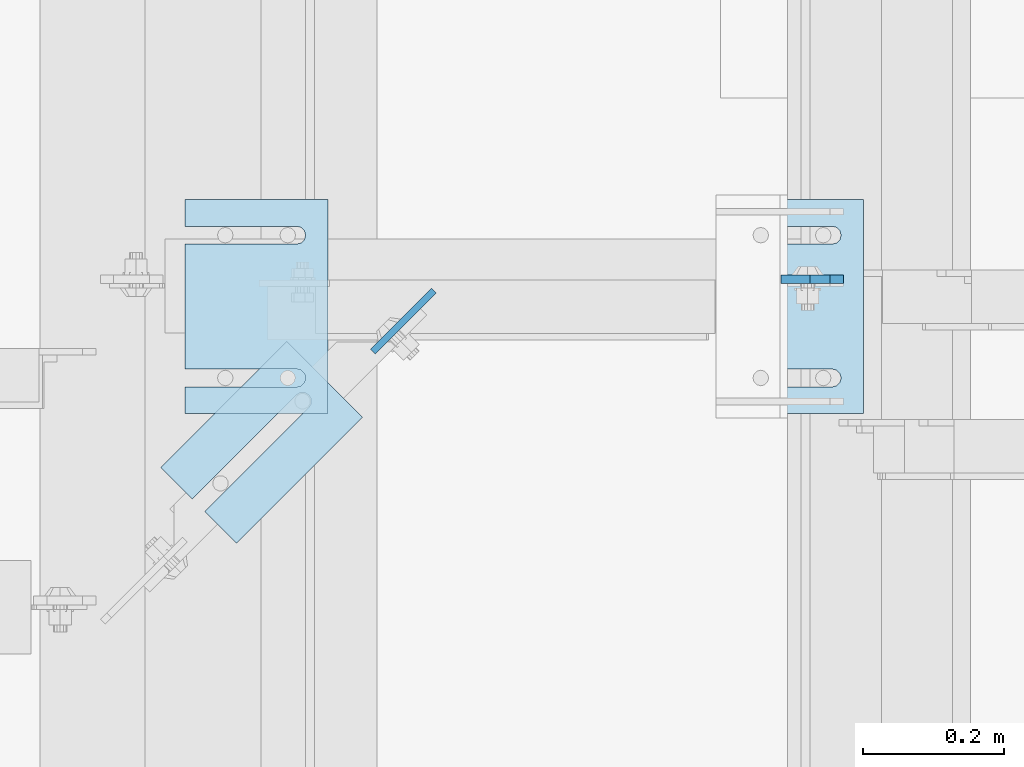
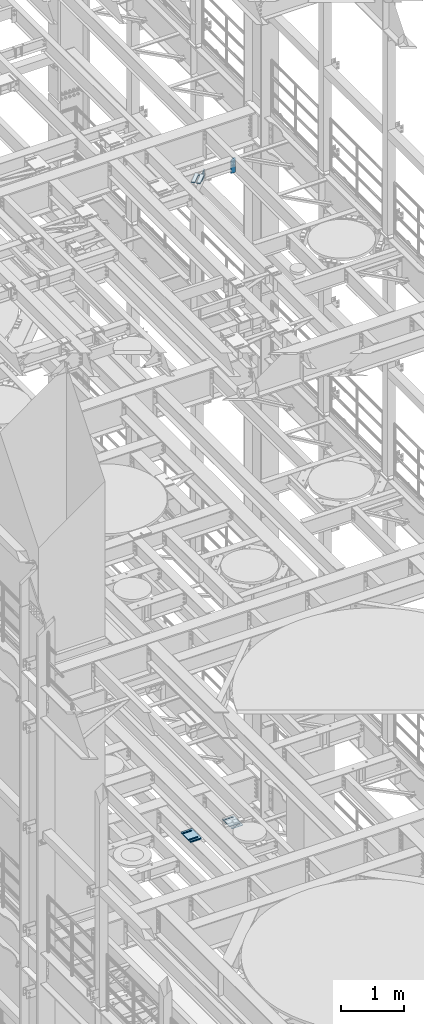
# One storey, part 1727 of 1876: 10 plates, 10 elements without a shape of their own.
"""IFC2X3 building model written with IfcOpenShell, lengths in millimetres."""

from ifc_helpers import new_model, si_unit, frame, origin_with_axes, place, context, subcontext, project, spatial, faceted_brep, material, type_object, element, aggregate, save


model = new_model("IFC2X3")

# Units and contexts
model_context = context("Model", 3, precision=1e-05, world=origin_with_axes())
body_context = subcontext(model_context, "Body", "Model", "MODEL_VIEW")
ifc_project = project(units=[si_unit("LENGTHUNIT", "METRE", prefix="MILLI"), si_unit("AREAUNIT", "SQUARE_METRE"), si_unit("VOLUMEUNIT", "CUBIC_METRE"), si_unit("MASSUNIT", "GRAM", prefix="KILO"), si_unit("TIMEUNIT", "SECOND"), si_unit("PLANEANGLEUNIT", "RADIAN"), si_unit("SOLIDANGLEUNIT", "STERADIAN"), si_unit("THERMODYNAMICTEMPERATUREUNIT", "DEGREE_CELSIUS"), si_unit("LUMINOUSINTENSITYUNIT", "LUMEN")], contexts=[model_context])

# Site, building, storey
site_placement = place(None, origin_with_axes())
site = spatial("IfcSite", under=ifc_project, at=site_placement, CompositionType="ELEMENT")
building_placement = place(site_placement, origin_with_axes())
building = spatial("IfcBuilding", under=site, at=building_placement, Name="Undefined", CompositionType="ELEMENT")
storey_placement = place(building_placement, origin_with_axes())
storey = spatial("IfcBuildingStorey", under=building, at=storey_placement, Name="Undefined", CompositionType="ELEMENT", Elevation=0.0)

# Assembly, plate
assembly_1_placement = place(storey_placement, origin_with_axes())
assembly_1 = element("IfcElementAssembly", 1, at=assembly_1_placement, inside=storey, Name="BEAM", AssemblyPlace="NOTDEFINED", PredefinedType="RIGID_FRAME")
ifc_material = material(Name="STEEL/A36")
plate_type_1 = type_object("IfcPlateType", PredefinedType="NOTDEFINED")
plate_1_placement = place(assembly_1_placement, frame((6562.72500011396, 6600.23089609146, 17686.3375), z_axis=(0.0, 0.0, 1.0), x_axis=(-1.0, 0.0, 0.0)))
plate_1 = element("IfcPlate", 2, at=plate_1_placement, type_object=plate_type_1, material=ifc_material, Name="PLATE", context=body_context, shape_type="Brep", body=[
    faceted_brep([(0.0, -6.35000000000196, 19.0499992370605), (0.0, -6.35000000000036, 271.462512969971), (0.0, 6.35000000000036, 271.462512969971), (0.0, 6.35000000000105, 19.0499992370605), (19.0499992370605, -6.35000000000036, 290.512512207031), (19.0499992370605, 6.35000000000036, 290.512512207031), (47.625, -6.35000000000036, 290.512512207031), (47.625, 6.35000000000036, 290.512512207031), (88.9000015258789, -6.35000000000036, 249.237510681152), (88.9000015258789, 6.35000000000036, 249.237510681152), (88.9000015258789, -6.34999999999991, 0.0), (88.9000015258789, 6.34999999999991, 0.0), (19.0499992370642, -6.35000000000105, 0.0), (19.0499992370633, 6.35000000000105, 0.0)], [[[0, 1, 2, 3]], [[1, 4, 5, 2]], [[4, 6, 7, 5]], [[6, 8, 9, 7]], [[8, 10, 11, 9]], [[10, 12, 13, 11]], [[12, 0, 3, 13]], [[5, 7, 9, 11, 13, 3, 2]], [[12, 10, 8, 6, 4, 1, 0]]]),
])
aggregate(assembly_1, [plate_1])

assembly_2_placement = place(storey_placement, origin_with_axes())
assembly_2 = element("IfcElementAssembly", 3, at=assembly_2_placement, inside=storey, Name="SHIM PLATE", AssemblyPlace="NOTDEFINED", PredefinedType="RIGID_FRAME")
plate_type_2 = type_object("IfcPlateType", PredefinedType="NOTDEFINED")
plate_2_placement = place(assembly_2_placement, frame((5770.7454778151, 6511.9559186681, 17987.9625), z_axis=(0.707131811743501, -0.707081749743517, 0.0), x_axis=(-0.707081749743517, -0.707131811743501, 0.0)))
plate_2 = element("IfcPlate", 4, at=plate_2_placement, type_object=plate_type_2, material=ifc_material, Name="SHIM PLATE", context=body_context, shape_type="Brep", body=[
    faceted_brep([(253.99911499016, -4.76250000000073, 63.5055228916333), (253.99911499016, 4.76250000000073, 63.5055228916333), (44.4486554352097, 4.76250000000073, 63.5055231271683), (44.4486554352097, -4.76250000000073, 63.5055231271683), (38.0987169747041, 4.76250000000073, 65.2072262109043), (38.0987169747041, -4.76250000000073, 65.2072262109043), (33.4503601482265, 4.76250000000073, 69.8559131923128), (33.4503601482265, -4.76250000000073, 69.8559131923128), (31.749108064505, 4.76250000000073, 76.2059724979433), (31.749108064505, -4.76250000000073, 76.2059724979433), (33.4508097177422, 4.76250000000073, 82.5559113418037), (33.4508097177422, -4.76250000000073, 82.5559113418037), (38.0994956519826, 4.76250000000073, 87.2042692155253), (38.0994956519826, -4.76250000000073, 87.2042692155253), (44.4495545743594, 4.76250000000073, 88.9055227297738), (44.4495545743594, -4.76250000000073, 88.9055227297738), (253.999114989845, -4.76250000000073, 88.8981048472285), (253.999114990162, 4.76250000000073, 88.8981048472285), (253.999114990156, -4.76250000000073, 2.95585778076202e-12), (0.0, -4.76249999999982, 0.0), (0.0, 4.76249999999982, 0.0), (253.999114990156, 4.76250000000073, 2.95585778076202e-12), (0.00539501897037553, -4.76250000000073, 152.405197143508), (0.00539501897037553, 4.76250000000073, 152.405197143508), (253.999114990165, -4.76250000000073, 152.405197143493), (253.999114990165, 4.76250000000073, 152.405197143493)], [[[0, 1, 2, 3]], [[3, 2, 4, 5]], [[5, 4, 6, 7]], [[7, 6, 8, 9]], [[9, 8, 10, 11]], [[11, 10, 12, 13]], [[13, 12, 14, 15]], [[16, 15, 14, 17]], [[18, 19, 20, 21]], [[19, 22, 23, 20]], [[22, 24, 25, 23]], [[25, 24, 16, 17]], [[12, 10, 8, 6, 4, 2, 1, 21, 20, 23, 25, 17, 14]], [[18, 21, 1, 0]], [[24, 22, 19, 18, 0, 3, 5, 7, 9, 11, 13, 15, 16]]]),
])
aggregate(assembly_2, [plate_2])

assembly_3_placement = place(storey_placement, origin_with_axes())
assembly_3 = element("IfcElementAssembly", 5, at=assembly_3_placement, inside=storey, Name="SHIM PLATE", AssemblyPlace="NOTDEFINED", PredefinedType="RIGID_FRAME")
plate_type_3 = type_object("IfcPlateType", PredefinedType="NOTDEFINED")
plate_3_placement = place(assembly_3_placement, frame((5829.30163873308, 6713.78228759766, 5156.9925), z_axis=(0.0, -1.0, 0.0), x_axis=(-1.0, 0.0, 0.0)))
plate_3 = element("IfcPlate", 6, at=plate_3_placement, type_object=plate_type_3, material=ifc_material, Name="SHIM PLATE", context=body_context, shape_type="Brep", body=[
    faceted_brep([(203.203060149864, -0.793499999999767, 38.103375484061), (203.203060149864, 0.793499999999767, 38.103375484061), (44.4515180349072, 0.793499999999767, 38.1033599194234), (44.4515180349072, -0.793499999999767, 38.1033599194234), (38.1012989900946, 0.793499999999767, 39.8049650059329), (38.1012989900946, -0.793499999999767, 39.8049650059329), (33.4527432566938, 0.793499999999767, 44.4538004924834), (33.4527432566938, -0.793499999999767, 44.4538004924834), (31.7515203221337, 0.793499999999767, 50.8041219264314), (31.7515203221337, -0.793499999999767, 50.8041219264314), (33.4535054350818, 0.793499999999767, 57.1542391271487), (33.4535054350818, -0.793499999999767, 57.1542391271487), (38.1026191065821, 0.793499999999767, 61.8025166422076), (38.1026191065821, -0.793499999999767, 61.8025166422076), (44.4530423390133, 0.793499999999767, 63.5033595381083), (44.4530423390133, -0.793499999999767, 63.5033595381083), (203.203057597802, -0.793499999999767, 63.5033693805453), (203.203057606771, 0.793499999999767, 63.5033693805453), (203.203063964842, -0.793499999999767, -8.45830072648823e-11), (9.09494701772928e-13, -0.793499999999767, 0.0), (9.09494701772928e-13, 0.793499999999767, 0.0), (203.203063964842, 0.793499999999767, -8.45830072648823e-11), (-1.83106603799388e-05, -0.793499999999767, 304.8037109375), (-1.83106603799388e-05, 0.793499999999767, 304.8037109375), (203.203033447349, -0.793499999999767, 304.803710937444), (203.203033447349, 0.793499999999767, 304.803710937444), (203.20303725321, -0.793499999999767, 266.701819087575), (203.203037262178, 0.793499999999767, 266.701819087575), (44.4530372532099, -0.793499999999767, 266.701809245139), (44.4530372532099, 0.793499999999767, 266.701809245139), (38.1026140207787, -0.793499999999767, 265.000966349239), (38.1026140207787, 0.793499999999767, 265.000966349239), (33.4535003492774, -0.793499999999767, 260.352688834179), (33.4535003492774, 0.793499999999767, 260.352688834179), (31.7515152363312, -0.793499999999767, 254.002571633462), (31.7515152363312, 0.793499999999767, 254.002571633462), (33.4527381708904, -0.793499999999767, 247.652250199514), (33.4527381708904, 0.793499999999767, 247.652250199514), (38.1012939042912, -0.793499999999767, 243.003414712964), (38.1012939042912, 0.793499999999767, 243.003414712964), (44.4515129491037, -0.793499999999767, 241.301809626454), (44.4515129491037, 0.793499999999767, 241.301809626454), (203.203039805271, -0.793499999999767, 241.301825191091), (203.203039805271, 0.793499999999767, 241.301825191091)], [[[0, 1, 2, 3]], [[3, 2, 4, 5]], [[5, 4, 6, 7]], [[7, 6, 8, 9]], [[9, 8, 10, 11]], [[11, 10, 12, 13]], [[13, 12, 14, 15]], [[16, 15, 14, 17]], [[18, 19, 20, 21]], [[19, 22, 23, 20]], [[22, 24, 25, 23]], [[25, 24, 26, 27]], [[26, 28, 29, 27]], [[30, 31, 29, 28]], [[32, 33, 31, 30]], [[34, 35, 33, 32]], [[36, 37, 35, 34]], [[38, 39, 37, 36]], [[40, 41, 39, 38]], [[42, 43, 41, 40]], [[43, 42, 16, 17]], [[12, 10, 8, 6, 4, 2, 1, 21, 20, 23, 25, 27, 29, 31, 33, 35, 37, 39, 41, 43, 17, 14]], [[18, 21, 1, 0]], [[42, 40, 38, 36, 34, 32, 30, 28, 26, 24, 22, 19, 18, 0, 3, 5, 7, 9, 11, 13, 15, 16]]]),
])
aggregate(assembly_3, [plate_3])

assembly_4_placement = place(storey_placement, origin_with_axes())
assembly_4 = element("IfcElementAssembly", 7, at=assembly_4_placement, inside=storey, Name="SHIM PLATE", AssemblyPlace="NOTDEFINED", PredefinedType="RIGID_FRAME")
plate_type_4 = type_object("IfcPlateType", PredefinedType="NOTDEFINED")
plate_4_placement = place(assembly_4_placement, frame((5829.30163873308, 6713.78228759766, 5154.6115), z_axis=(0.0, -1.0, 0.0), x_axis=(-1.0, 0.0, 0.0)))
plate_4 = element("IfcPlate", 8, at=plate_4_placement, type_object=plate_type_4, material=ifc_material, Name="SHIM PLATE", context=body_context, shape_type="Brep", body=[
    faceted_brep([(203.203060149865, -1.58749999999964, 38.1033754840619), (203.203060149865, 1.58749999999964, 38.1033754840619), (44.4515180349081, 1.58749999999964, 38.1033599194243), (44.4515180349081, -1.58749999999964, 38.1033599194243), (38.1012989900955, 1.58749999999964, 39.8049650059338), (38.1012989900955, -1.58749999999964, 39.8049650059338), (33.4527432566947, 1.58749999999964, 44.4538004924843), (33.4527432566947, -1.58749999999964, 44.4538004924843), (31.7515203221346, 1.58749999999964, 50.8041219264323), (31.7515203221346, -1.58749999999964, 50.8041219264323), (33.4535054350827, 1.58749999999964, 57.1542391271496), (33.4535054350827, -1.58749999999964, 57.1542391271496), (38.102619106583, 1.58749999999964, 61.8025166422085), (38.102619106583, -1.58749999999964, 61.8025166422085), (44.4530423390142, 1.58749999999964, 63.5033595381092), (44.4530423390142, -1.58749999999964, 63.5033595381092), (203.203057597803, -1.58749999999964, 63.5033693805462), (203.203057606772, 1.58749999999964, 63.5033693805462), (203.203063964843, -1.58749999999964, -8.36735125631094e-11), (9.09494701772928e-13, -1.58750000000146, 4.54747350886464e-13), (9.09494701772928e-13, 1.58750000000146, 4.54747350886464e-13), (203.203063964843, 1.58749999999964, -8.36735125631094e-11), (-1.83106631084229e-05, -1.58749999999964, 304.803710937501), (-1.83106631084229e-05, 1.58749999999964, 304.803710937501), (203.20303344735, -1.58749999999964, 304.803710937445), (203.20303344735, 1.58749999999964, 304.803710937445), (203.203037253211, -1.58749999999964, 266.701819087576), (203.203037262179, 1.58749999999964, 266.701819087576), (44.4530372532108, -1.58749999999964, 266.70180924514), (44.4530372532108, 1.58749999999964, 266.70180924514), (38.1026140207796, -1.58749999999964, 265.00096634924), (38.1026140207796, 1.58749999999964, 265.00096634924), (33.4535003492783, -1.58749999999964, 260.35268883418), (33.4535003492783, 1.58749999999964, 260.35268883418), (31.7515152363321, -1.58749999999964, 254.002571633463), (31.7515152363321, 1.58749999999964, 254.002571633463), (33.4527381708913, -1.58749999999964, 247.652250199515), (33.4527381708913, 1.58749999999964, 247.652250199515), (38.1012939042921, -1.58749999999964, 243.003414712965), (38.1012939042921, 1.58749999999964, 243.003414712965), (44.4515129491047, -1.58749999999964, 241.301809626455), (44.4515129491047, 1.58749999999964, 241.301809626455), (203.203039805272, -1.58749999999964, 241.301825191092), (203.203039805272, 1.58749999999964, 241.301825191092)], [[[0, 1, 2, 3]], [[3, 2, 4, 5]], [[5, 4, 6, 7]], [[7, 6, 8, 9]], [[9, 8, 10, 11]], [[11, 10, 12, 13]], [[13, 12, 14, 15]], [[16, 15, 14, 17]], [[18, 19, 20, 21]], [[19, 22, 23, 20]], [[22, 24, 25, 23]], [[25, 24, 26, 27]], [[26, 28, 29, 27]], [[30, 31, 29, 28]], [[32, 33, 31, 30]], [[34, 35, 33, 32]], [[36, 37, 35, 34]], [[38, 39, 37, 36]], [[40, 41, 39, 38]], [[42, 43, 41, 40]], [[43, 42, 16, 17]], [[12, 10, 8, 6, 4, 2, 1, 21, 20, 23, 25, 27, 29, 31, 33, 35, 37, 39, 41, 43, 17, 14]], [[18, 21, 1, 0]], [[42, 40, 38, 36, 34, 32, 30, 28, 26, 24, 22, 19, 18, 0, 3, 5, 7, 9, 11, 13, 15, 16]]]),
])
aggregate(assembly_4, [plate_4])

assembly_5_placement = place(storey_placement, origin_with_axes())
assembly_5 = element("IfcElementAssembly", 9, at=assembly_5_placement, inside=storey, Name="SHIM PLATE", AssemblyPlace="NOTDEFINED", PredefinedType="RIGID_FRAME")
plate_5_placement = place(assembly_5_placement, frame((5829.30163873308, 6713.78228759766, 5151.4365), z_axis=(0.0, -1.0, 0.0), x_axis=(-1.0, 0.0, 0.0)))
plate_5 = element("IfcPlate", 10, at=plate_5_placement, type_object=plate_type_4, material=ifc_material, Name="SHIM PLATE", context=body_context, shape_type="Brep", body=[
    faceted_brep([(203.203060149865, -1.58749999999964, 38.1033754840619), (203.203060149865, 1.58749999999964, 38.1033754840619), (44.4515180349081, 1.58749999999964, 38.1033599194243), (44.4515180349081, -1.58749999999964, 38.1033599194243), (38.1012989900955, 1.58749999999964, 39.8049650059338), (38.1012989900955, -1.58749999999964, 39.8049650059338), (33.4527432566947, 1.58749999999964, 44.4538004924843), (33.4527432566947, -1.58749999999964, 44.4538004924843), (31.7515203221346, 1.58749999999964, 50.8041219264323), (31.7515203221346, -1.58749999999964, 50.8041219264323), (33.4535054350827, 1.58749999999964, 57.1542391271496), (33.4535054350827, -1.58749999999964, 57.1542391271496), (38.102619106583, 1.58749999999964, 61.8025166422085), (38.102619106583, -1.58749999999964, 61.8025166422085), (44.4530423390142, 1.58749999999964, 63.5033595381092), (44.4530423390142, -1.58749999999964, 63.5033595381092), (203.203057597803, -1.58749999999964, 63.5033693805462), (203.203057606772, 1.58749999999964, 63.5033693805462), (203.203063964843, -1.58749999999964, -8.36735125631094e-11), (9.09494701772928e-13, -1.58750000000146, 4.54747350886464e-13), (9.09494701772928e-13, 1.58750000000146, 4.54747350886464e-13), (203.203063964843, 1.58749999999964, -8.36735125631094e-11), (-1.83106631084229e-05, -1.58749999999964, 304.803710937501), (-1.83106631084229e-05, 1.58749999999964, 304.803710937501), (203.20303344735, -1.58749999999964, 304.803710937445), (203.20303344735, 1.58749999999964, 304.803710937445), (203.203037253211, -1.58749999999964, 266.701819087576), (203.203037262179, 1.58749999999964, 266.701819087576), (44.4530372532108, -1.58749999999964, 266.70180924514), (44.4530372532108, 1.58749999999964, 266.70180924514), (38.1026140207796, -1.58749999999964, 265.00096634924), (38.1026140207796, 1.58749999999964, 265.00096634924), (33.4535003492783, -1.58749999999964, 260.35268883418), (33.4535003492783, 1.58749999999964, 260.35268883418), (31.7515152363321, -1.58749999999964, 254.002571633463), (31.7515152363321, 1.58749999999964, 254.002571633463), (33.4527381708913, -1.58749999999964, 247.652250199515), (33.4527381708913, 1.58749999999964, 247.652250199515), (38.1012939042921, -1.58749999999964, 243.003414712965), (38.1012939042921, 1.58749999999964, 243.003414712965), (44.4515129491047, -1.58749999999964, 241.301809626455), (44.4515129491047, 1.58749999999964, 241.301809626455), (203.203039805272, -1.58749999999964, 241.301825191092), (203.203039805272, 1.58749999999964, 241.301825191092)], [[[0, 1, 2, 3]], [[3, 2, 4, 5]], [[5, 4, 6, 7]], [[7, 6, 8, 9]], [[9, 8, 10, 11]], [[11, 10, 12, 13]], [[13, 12, 14, 15]], [[16, 15, 14, 17]], [[18, 19, 20, 21]], [[19, 22, 23, 20]], [[22, 24, 25, 23]], [[25, 24, 26, 27]], [[26, 28, 29, 27]], [[30, 31, 29, 28]], [[32, 33, 31, 30]], [[34, 35, 33, 32]], [[36, 37, 35, 34]], [[38, 39, 37, 36]], [[40, 41, 39, 38]], [[42, 43, 41, 40]], [[43, 42, 16, 17]], [[12, 10, 8, 6, 4, 2, 1, 21, 20, 23, 25, 27, 29, 31, 33, 35, 37, 39, 41, 43, 17, 14]], [[18, 21, 1, 0]], [[42, 40, 38, 36, 34, 32, 30, 28, 26, 24, 22, 19, 18, 0, 3, 5, 7, 9, 11, 13, 15, 16]]]),
])
aggregate(assembly_5, [plate_5])

assembly_6_placement = place(storey_placement, origin_with_axes())
assembly_6 = element("IfcElementAssembly", 11, at=assembly_6_placement, inside=storey, Name="SHIM PLATE", AssemblyPlace="NOTDEFINED", PredefinedType="RIGID_FRAME")
plate_type_5 = type_object("IfcPlateType", PredefinedType="NOTDEFINED")
plate_6_placement = place(assembly_6_placement, frame((5829.30163873308, 6713.78228759766, 5147.468), z_axis=(0.0, -1.0, 0.0), x_axis=(-1.0, 0.0, 0.0)))
plate_6 = element("IfcPlate", 12, at=plate_6_placement, type_object=plate_type_5, material=ifc_material, Name="SHIM PLATE", context=body_context, shape_type="Brep", body=[
    faceted_brep([(203.203060149865, -2.38100000000031, 38.1033754840619), (203.203060149865, 2.38100000000031, 38.1033754840619), (44.4515180349081, 2.38100000000031, 38.1033599194243), (44.4515180349081, -2.38100000000031, 38.1033599194243), (38.1012989900955, 2.38100000000031, 39.8049650059338), (38.1012989900955, -2.38100000000031, 39.8049650059338), (33.4527432566947, 2.38100000000031, 44.4538004924843), (33.4527432566947, -2.38100000000031, 44.4538004924843), (31.7515203221346, 2.38100000000031, 50.8041219264323), (31.7515203221346, -2.38100000000031, 50.8041219264323), (33.4535054350827, 2.38100000000031, 57.1542391271496), (33.4535054350827, -2.38100000000031, 57.1542391271496), (38.102619106583, 2.38100000000031, 61.8025166422085), (38.102619106583, -2.38100000000031, 61.8025166422085), (44.4530423390142, 2.38100000000031, 63.5033595381092), (44.4530423390142, -2.38100000000031, 63.5033595381092), (203.203057597803, -2.38100000000031, 63.5033693805462), (203.203057606772, 2.38100000000031, 63.5033693805462), (203.203063964843, -2.38100000000031, -8.36735125631094e-11), (0.0, -2.38100000000122, 4.54747350886464e-13), (0.0, 2.38100000000122, 4.54747350886464e-13), (203.203063964843, 2.38100000000031, -8.36735125631094e-11), (-1.83106667464017e-05, -2.38100000000031, 304.803710937501), (-1.83106667464017e-05, 2.38100000000031, 304.803710937501), (203.20303344735, -2.38100000000031, 304.803710937445), (203.20303344735, 2.38100000000031, 304.803710937445), (203.203037253211, -2.38100000000031, 266.701819087576), (203.203037262179, 2.38100000000031, 266.701819087576), (44.4530372532108, -2.38100000000031, 266.70180924514), (44.4530372532108, 2.38100000000031, 266.70180924514), (38.1026140207796, -2.38100000000031, 265.00096634924), (38.1026140207796, 2.38100000000031, 265.00096634924), (33.4535003492783, -2.38100000000031, 260.35268883418), (33.4535003492783, 2.38100000000031, 260.35268883418), (31.7515152363321, -2.38100000000031, 254.002571633463), (31.7515152363321, 2.38100000000031, 254.002571633463), (33.4527381708913, -2.38100000000031, 247.652250199515), (33.4527381708913, 2.38100000000031, 247.652250199515), (38.1012939042921, -2.38100000000031, 243.003414712965), (38.1012939042921, 2.38100000000031, 243.003414712965), (44.4515129491047, -2.38100000000031, 241.301809626455), (44.4515129491047, 2.38100000000031, 241.301809626455), (203.203039805272, -2.38100000000031, 241.301825191092), (203.203039805272, 2.38100000000031, 241.301825191092)], [[[0, 1, 2, 3]], [[3, 2, 4, 5]], [[5, 4, 6, 7]], [[7, 6, 8, 9]], [[9, 8, 10, 11]], [[11, 10, 12, 13]], [[13, 12, 14, 15]], [[16, 15, 14, 17]], [[18, 19, 20, 21]], [[19, 22, 23, 20]], [[22, 24, 25, 23]], [[25, 24, 26, 27]], [[26, 28, 29, 27]], [[30, 31, 29, 28]], [[32, 33, 31, 30]], [[34, 35, 33, 32]], [[36, 37, 35, 34]], [[38, 39, 37, 36]], [[40, 41, 39, 38]], [[42, 43, 41, 40]], [[43, 42, 16, 17]], [[12, 10, 8, 6, 4, 2, 1, 21, 20, 23, 25, 27, 29, 31, 33, 35, 37, 39, 41, 43, 17, 14]], [[18, 21, 1, 0]], [[42, 40, 38, 36, 34, 32, 30, 28, 26, 24, 22, 19, 18, 0, 3, 5, 7, 9, 11, 13, 15, 16]]]),
])
aggregate(assembly_6, [plate_6])

assembly_7_placement = place(storey_placement, origin_with_axes())
assembly_7 = element("IfcElementAssembly", 13, at=assembly_7_placement, inside=storey, Name="SHIM PLATE", AssemblyPlace="NOTDEFINED", PredefinedType="RIGID_FRAME")
plate_7_placement = place(assembly_7_placement, frame((5829.30163873308, 6713.78228759766, 5142.706), z_axis=(0.0, -1.0, 0.0), x_axis=(-1.0, 0.0, 0.0)))
plate_7 = element("IfcPlate", 14, at=plate_7_placement, type_object=plate_type_5, material=ifc_material, Name="SHIM PLATE", context=body_context, shape_type="Brep", body=[
    faceted_brep([(203.203060149865, -2.38100000000031, 38.1033754840619), (203.203060149865, 2.38100000000031, 38.1033754840619), (44.4515180349081, 2.38100000000031, 38.1033599194243), (44.4515180349081, -2.38100000000031, 38.1033599194243), (38.1012989900955, 2.38100000000031, 39.8049650059338), (38.1012989900955, -2.38100000000031, 39.8049650059338), (33.4527432566947, 2.38100000000031, 44.4538004924843), (33.4527432566947, -2.38100000000031, 44.4538004924843), (31.7515203221346, 2.38100000000031, 50.8041219264323), (31.7515203221346, -2.38100000000031, 50.8041219264323), (33.4535054350827, 2.38100000000031, 57.1542391271496), (33.4535054350827, -2.38100000000031, 57.1542391271496), (38.102619106583, 2.38100000000031, 61.8025166422085), (38.102619106583, -2.38100000000031, 61.8025166422085), (44.4530423390142, 2.38100000000031, 63.5033595381092), (44.4530423390142, -2.38100000000031, 63.5033595381092), (203.203057597803, -2.38100000000031, 63.5033693805462), (203.203057606772, 2.38100000000031, 63.5033693805462), (203.203063964843, -2.38100000000031, -8.36735125631094e-11), (0.0, -2.38100000000122, 4.54747350886464e-13), (0.0, 2.38100000000122, 4.54747350886464e-13), (203.203063964843, 2.38100000000031, -8.36735125631094e-11), (-1.83106667464017e-05, -2.38100000000031, 304.803710937501), (-1.83106667464017e-05, 2.38100000000031, 304.803710937501), (203.20303344735, -2.38100000000031, 304.803710937445), (203.20303344735, 2.38100000000031, 304.803710937445), (203.203037253211, -2.38100000000031, 266.701819087576), (203.203037262179, 2.38100000000031, 266.701819087576), (44.4530372532108, -2.38100000000031, 266.70180924514), (44.4530372532108, 2.38100000000031, 266.70180924514), (38.1026140207796, -2.38100000000031, 265.00096634924), (38.1026140207796, 2.38100000000031, 265.00096634924), (33.4535003492783, -2.38100000000031, 260.35268883418), (33.4535003492783, 2.38100000000031, 260.35268883418), (31.7515152363321, -2.38100000000031, 254.002571633463), (31.7515152363321, 2.38100000000031, 254.002571633463), (33.4527381708913, -2.38100000000031, 247.652250199515), (33.4527381708913, 2.38100000000031, 247.652250199515), (38.1012939042921, -2.38100000000031, 243.003414712965), (38.1012939042921, 2.38100000000031, 243.003414712965), (44.4515129491047, -2.38100000000031, 241.301809626455), (44.4515129491047, 2.38100000000031, 241.301809626455), (203.203039805272, -2.38100000000031, 241.301825191092), (203.203039805272, 2.38100000000031, 241.301825191092)], [[[0, 1, 2, 3]], [[3, 2, 4, 5]], [[5, 4, 6, 7]], [[7, 6, 8, 9]], [[9, 8, 10, 11]], [[11, 10, 12, 13]], [[13, 12, 14, 15]], [[16, 15, 14, 17]], [[18, 19, 20, 21]], [[19, 22, 23, 20]], [[22, 24, 25, 23]], [[25, 24, 26, 27]], [[26, 28, 29, 27]], [[30, 31, 29, 28]], [[32, 33, 31, 30]], [[34, 35, 33, 32]], [[36, 37, 35, 34]], [[38, 39, 37, 36]], [[40, 41, 39, 38]], [[42, 43, 41, 40]], [[43, 42, 16, 17]], [[12, 10, 8, 6, 4, 2, 1, 21, 20, 23, 25, 27, 29, 31, 33, 35, 37, 39, 41, 43, 17, 14]], [[18, 21, 1, 0]], [[42, 40, 38, 36, 34, 32, 30, 28, 26, 24, 22, 19, 18, 0, 3, 5, 7, 9, 11, 13, 15, 16]]]),
])
aggregate(assembly_7, [plate_7])

assembly_8_placement = place(storey_placement, origin_with_axes())
assembly_8 = element("IfcElementAssembly", 15, at=assembly_8_placement, inside=storey, Name="SHIM PLATE", AssemblyPlace="NOTDEFINED", PredefinedType="RIGID_FRAME")
plate_type_6 = type_object("IfcPlateType", PredefinedType="NOTDEFINED")
plate_8_placement = place(assembly_8_placement, frame((6591.29886163347, 6713.78228759766, 5135.5625), z_axis=(0.0, -1.0, 0.0), x_axis=(-1.0, 0.0, 0.0)))
plate_8 = element("IfcPlate", 16, at=plate_8_placement, type_object=plate_type_6, material=ifc_material, Name="SHIM PLATE", context=body_context, shape_type="Brep", body=[
    faceted_brep([(203.203060149865, -4.76249999999982, 38.1033754840619), (203.203060149865, 4.76249999999982, 38.1033754840619), (44.4515180349081, 4.76249999999982, 38.1033599194243), (44.4515180349081, -4.76249999999982, 38.1033599194243), (38.1012989900955, 4.76249999999982, 39.8049650059338), (38.1012989900955, -4.76249999999982, 39.8049650059338), (33.4527432566947, 4.76249999999982, 44.4538004924843), (33.4527432566947, -4.76249999999982, 44.4538004924843), (31.7515203221346, 4.76249999999982, 50.8041219264323), (31.7515203221346, -4.76249999999982, 50.8041219264323), (33.4535054350827, 4.76249999999982, 57.1542391271496), (33.4535054350827, -4.76249999999982, 57.1542391271496), (38.102619106583, 4.76249999999982, 61.8025166422085), (38.102619106583, -4.76249999999982, 61.8025166422085), (44.4530423390142, 4.76249999999982, 63.5033595381092), (44.4530423390142, -4.76249999999982, 63.5033595381092), (203.203057597803, -4.76249999999982, 63.5033693805462), (203.203057606772, 4.76249999999982, 63.5033693805462), (203.203063964843, -4.76249999999982, -8.36735125631094e-11), (0.0, -4.76249999999982, 0.0), (0.0, 4.76249999999982, 0.0), (203.203063964843, 4.76249999999982, -8.36735125631094e-11), (-1.83106703843805e-05, -4.76249999999982, 304.803710937501), (-1.83106703843805e-05, 4.76249999999982, 304.803710937501), (203.20303344735, -4.76249999999982, 304.803710937445), (203.20303344735, 4.76249999999982, 304.803710937445), (203.203037253211, -4.76249999999982, 266.701819087576), (203.203037262179, 4.76249999999982, 266.701819087576), (44.4530372532108, -4.76249999999982, 266.70180924514), (44.4530372532108, 4.76249999999982, 266.70180924514), (38.1026140207796, -4.76249999999982, 265.00096634924), (38.1026140207796, 4.76249999999982, 265.00096634924), (33.4535003492783, -4.76249999999982, 260.35268883418), (33.4535003492783, 4.76249999999982, 260.35268883418), (31.7515152363321, -4.76249999999982, 254.002571633463), (31.7515152363321, 4.76249999999982, 254.002571633463), (33.4527381708913, -4.76249999999982, 247.652250199515), (33.4527381708913, 4.76249999999982, 247.652250199515), (38.1012939042921, -4.76249999999982, 243.003414712965), (38.1012939042921, 4.76249999999982, 243.003414712965), (44.4515129491047, -4.76249999999982, 241.301809626455), (44.4515129491047, 4.76249999999982, 241.301809626455), (203.203039805272, -4.76249999999982, 241.301825191092), (203.203039805272, 4.76249999999982, 241.301825191092)], [[[0, 1, 2, 3]], [[3, 2, 4, 5]], [[5, 4, 6, 7]], [[7, 6, 8, 9]], [[9, 8, 10, 11]], [[11, 10, 12, 13]], [[13, 12, 14, 15]], [[16, 15, 14, 17]], [[18, 19, 20, 21]], [[19, 22, 23, 20]], [[22, 24, 25, 23]], [[25, 24, 26, 27]], [[26, 28, 29, 27]], [[30, 31, 29, 28]], [[32, 33, 31, 30]], [[34, 35, 33, 32]], [[36, 37, 35, 34]], [[38, 39, 37, 36]], [[40, 41, 39, 38]], [[42, 43, 41, 40]], [[43, 42, 16, 17]], [[12, 10, 8, 6, 4, 2, 1, 21, 20, 23, 25, 27, 29, 31, 33, 35, 37, 39, 41, 43, 17, 14]], [[18, 21, 1, 0]], [[42, 40, 38, 36, 34, 32, 30, 28, 26, 24, 22, 19, 18, 0, 3, 5, 7, 9, 11, 13, 15, 16]]]),
])
aggregate(assembly_8, [plate_8])

assembly_9_placement = place(storey_placement, origin_with_axes())
assembly_9 = element("IfcElementAssembly", 17, at=assembly_9_placement, inside=storey, Name="SHIM PLATE", AssemblyPlace="NOTDEFINED", PredefinedType="RIGID_FRAME")
plate_9_placement = place(assembly_9_placement, frame((5829.30163873308, 6713.78228759765, 5135.5625), z_axis=(0.0, -1.0, 0.0), x_axis=(-1.0, 0.0, 0.0)))
plate_9 = element("IfcPlate", 18, at=plate_9_placement, type_object=plate_type_6, material=ifc_material, Name="SHIM PLATE", context=body_context, shape_type="Brep", body=[
    faceted_brep([(203.203060149865, -4.76249999999982, 38.1033754840619), (203.203060149865, 4.76249999999982, 38.1033754840619), (44.4515180349081, 4.76249999999982, 38.1033599194243), (44.4515180349081, -4.76249999999982, 38.1033599194243), (38.1012989900955, 4.76249999999982, 39.8049650059338), (38.1012989900955, -4.76249999999982, 39.8049650059338), (33.4527432566947, 4.76249999999982, 44.4538004924843), (33.4527432566947, -4.76249999999982, 44.4538004924843), (31.7515203221346, 4.76249999999982, 50.8041219264323), (31.7515203221346, -4.76249999999982, 50.8041219264323), (33.4535054350827, 4.76249999999982, 57.1542391271496), (33.4535054350827, -4.76249999999982, 57.1542391271496), (38.102619106583, 4.76249999999982, 61.8025166422085), (38.102619106583, -4.76249999999982, 61.8025166422085), (44.4530423390142, 4.76249999999982, 63.5033595381092), (44.4530423390142, -4.76249999999982, 63.5033595381092), (203.203057597803, -4.76249999999982, 63.5033693805462), (203.203057606772, 4.76249999999982, 63.5033693805462), (203.203063964843, -4.76249999999982, -8.36735125631094e-11), (0.0, -4.76249999999982, 0.0), (0.0, 4.76249999999982, 0.0), (203.203063964843, 4.76249999999982, -8.36735125631094e-11), (-1.83106703843805e-05, -4.76249999999982, 304.803710937501), (-1.83106703843805e-05, 4.76249999999982, 304.803710937501), (203.20303344735, -4.76249999999982, 304.803710937445), (203.20303344735, 4.76249999999982, 304.803710937445), (203.203037253211, -4.76249999999982, 266.701819087576), (203.203037262179, 4.76249999999982, 266.701819087576), (44.4530372532108, -4.76249999999982, 266.70180924514), (44.4530372532108, 4.76249999999982, 266.70180924514), (38.1026140207796, -4.76249999999982, 265.00096634924), (38.1026140207796, 4.76249999999982, 265.00096634924), (33.4535003492783, -4.76249999999982, 260.35268883418), (33.4535003492783, 4.76249999999982, 260.35268883418), (31.7515152363321, -4.76249999999982, 254.002571633463), (31.7515152363321, 4.76249999999982, 254.002571633463), (33.4527381708913, -4.76249999999982, 247.652250199515), (33.4527381708913, 4.76249999999982, 247.652250199515), (38.1012939042921, -4.76249999999982, 243.003414712965), (38.1012939042921, 4.76249999999982, 243.003414712965), (44.4515129491047, -4.76249999999982, 241.301809626455), (44.4515129491047, 4.76249999999982, 241.301809626455), (203.203039805272, -4.76249999999982, 241.301825191092), (203.203039805272, 4.76249999999982, 241.301825191092)], [[[0, 1, 2, 3]], [[3, 2, 4, 5]], [[5, 4, 6, 7]], [[7, 6, 8, 9]], [[9, 8, 10, 11]], [[11, 10, 12, 13]], [[13, 12, 14, 15]], [[16, 15, 14, 17]], [[18, 19, 20, 21]], [[19, 22, 23, 20]], [[22, 24, 25, 23]], [[25, 24, 26, 27]], [[26, 28, 29, 27]], [[30, 31, 29, 28]], [[32, 33, 31, 30]], [[34, 35, 33, 32]], [[36, 37, 35, 34]], [[38, 39, 37, 36]], [[40, 41, 39, 38]], [[42, 43, 41, 40]], [[43, 42, 16, 17]], [[12, 10, 8, 6, 4, 2, 1, 21, 20, 23, 25, 27, 29, 31, 33, 35, 37, 39, 41, 43, 17, 14]], [[18, 21, 1, 0]], [[42, 40, 38, 36, 34, 32, 30, 28, 26, 24, 22, 19, 18, 0, 3, 5, 7, 9, 11, 13, 15, 16]]]),
])
aggregate(assembly_9, [plate_9])

assembly_10_placement = place(storey_placement, origin_with_axes())
assembly_10 = element("IfcElementAssembly", 19, at=assembly_10_placement, inside=storey, Name="BEAM", AssemblyPlace="NOTDEFINED", PredefinedType="RIGID_FRAME")
plate_type_7 = type_object("IfcPlateType", PredefinedType="NOTDEFINED")
plate_10_placement = place(assembly_10_placement, frame((5979.8316586176, 6584.16329995069, 17957.8), z_axis=(-0.707106781186547, -0.707106781186548, 0.0), x_axis=(0.0, 0.0, -1.0)))
plate_10 = element("IfcPlate", 20, at=plate_10_placement, type_object=plate_type_7, material=ifc_material, Name="PLATE", context=body_context, shape_type="Brep", body=[
    faceted_brep([(0.0, -4.76249999999982, 0.0), (0.0, -4.76250000000147, 122.735206604024), (0.0, 4.7625000000009, 122.735206604024), (0.0, 4.76249999999982, 0.0), (152.399993896484, -4.76250000000147, 122.735206604024), (152.399993896484, 4.7625000000009, 122.735206604024), (152.399993896484, -4.76249999999982, 0.0), (152.399993896484, 4.76249999999982, 0.0)], [[[0, 1, 2, 3]], [[1, 4, 5, 2]], [[4, 6, 7, 5]], [[6, 0, 3, 7]], [[5, 7, 3, 2]], [[6, 4, 1, 0]]]),
])
aggregate(assembly_10, [plate_10])

save(model, "model.ifc")
